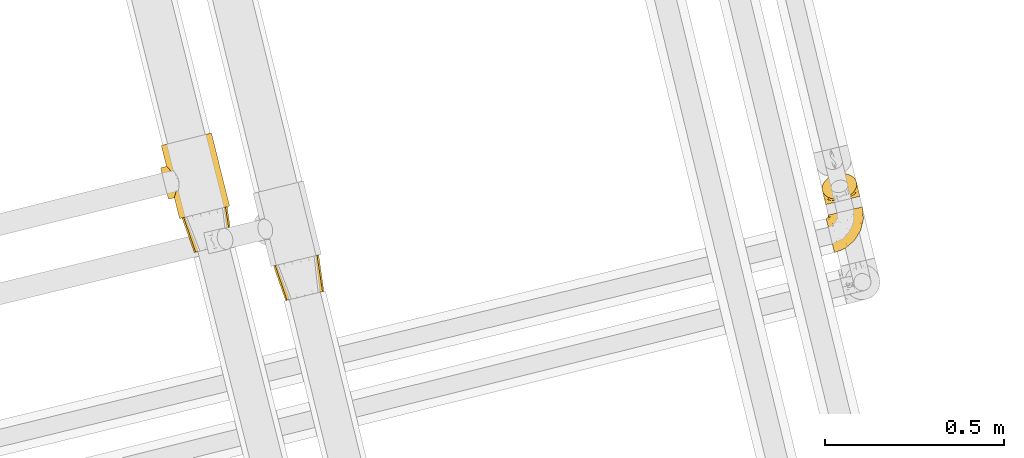
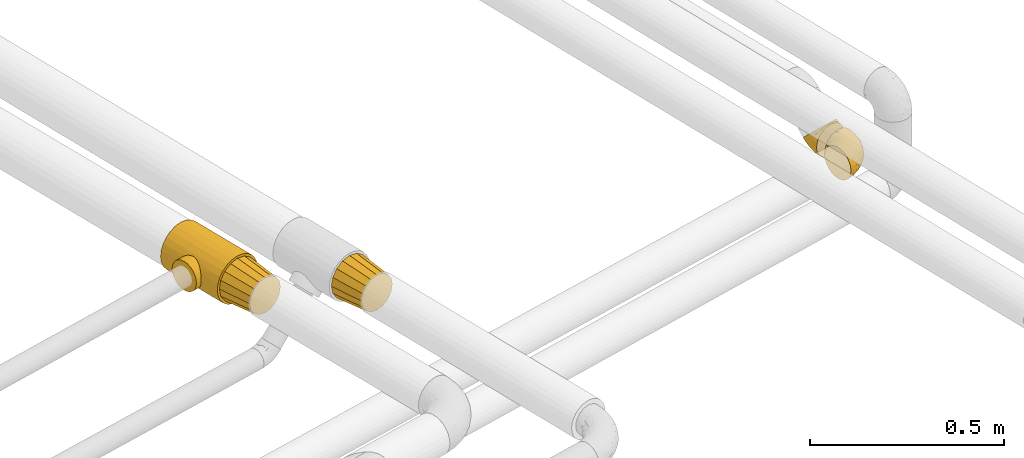
# One storey, part 7 of 93: 5 coverings.
"""IFC2X3 building model written with IfcOpenShell, lengths in millimetres."""

from ifc_helpers import new_model, entity, si_unit, converted_unit, derived_unit, direction, frame, origin, place, context, subcontext, project, spatial, faceted_brep, element, save


model = new_model("IFC2X3")

# Units and contexts
model_context = context("Model", 3, precision=0.01, world=origin(), true_north=direction((6.12303176911189e-17, 1.0)))
body_context = subcontext(model_context, "Body", "Model", "MODEL_VIEW")
ifc_project = project(units=[si_unit("LENGTHUNIT", "METRE", prefix="MILLI"), si_unit("AREAUNIT", "SQUARE_METRE"), si_unit("VOLUMEUNIT", "CUBIC_METRE"), converted_unit("PLANEANGLEUNIT", "DEGREE", entity("IfcRatioMeasure", 0.0174532925199433), si_unit("PLANEANGLEUNIT", "RADIAN"), dimensions=[0, 0, 0, 0, 0, 0, 0]), si_unit("MASSUNIT", "GRAM", prefix="KILO"), derived_unit("MASSDENSITYUNIT", [(si_unit("MASSUNIT", "GRAM", prefix="KILO"), 1), (si_unit("LENGTHUNIT", "METRE"), -3)]), derived_unit("MOMENTOFINERTIAUNIT", [(si_unit("LENGTHUNIT", "METRE"), 4)]), si_unit("TIMEUNIT", "SECOND"), si_unit("FREQUENCYUNIT", "HERTZ"), si_unit("THERMODYNAMICTEMPERATUREUNIT", "DEGREE_CELSIUS"), derived_unit("THERMALTRANSMITTANCEUNIT", [(si_unit("MASSUNIT", "GRAM", prefix="KILO"), 1), (si_unit("THERMODYNAMICTEMPERATUREUNIT", "KELVIN"), -1), (si_unit("TIMEUNIT", "SECOND"), -3)]), derived_unit("VOLUMETRICFLOWRATEUNIT", [(si_unit("LENGTHUNIT", "METRE"), 3), (si_unit("TIMEUNIT", "SECOND"), -1)]), derived_unit("MASSFLOWRATEUNIT", [(si_unit("MASSUNIT", "GRAM", prefix="KILO"), 1), (si_unit("TIMEUNIT", "SECOND"), -1)]), derived_unit("ROTATIONALFREQUENCYUNIT", [(si_unit("TIMEUNIT", "SECOND"), -1)]), si_unit("ELECTRICCURRENTUNIT", "AMPERE"), si_unit("ELECTRICVOLTAGEUNIT", "VOLT"), si_unit("POWERUNIT", "WATT"), si_unit("FORCEUNIT", "NEWTON", prefix="KILO"), si_unit("ILLUMINANCEUNIT", "LUX"), si_unit("LUMINOUSFLUXUNIT", "LUMEN"), si_unit("LUMINOUSINTENSITYUNIT", "CANDELA"), derived_unit("USERDEFINED", [(si_unit("MASSUNIT", "GRAM", prefix="KILO"), -1), (si_unit("LENGTHUNIT", "METRE"), -2), (si_unit("TIMEUNIT", "SECOND"), 3), (si_unit("LUMINOUSFLUXUNIT", "LUMEN"), 1)]), derived_unit("LINEARVELOCITYUNIT", [(si_unit("LENGTHUNIT", "METRE"), 1), (si_unit("TIMEUNIT", "SECOND"), -1)]), si_unit("PRESSUREUNIT", "PASCAL"), derived_unit("USERDEFINED", [(si_unit("LENGTHUNIT", "METRE"), -2), (si_unit("MASSUNIT", "GRAM", prefix="KILO"), 1), (si_unit("TIMEUNIT", "SECOND"), -2)]), derived_unit("LINEARFORCEUNIT", [(si_unit("MASSUNIT", "GRAM", prefix="KILO"), 1), (si_unit("LENGTHUNIT", "METRE"), 1), (si_unit("TIMEUNIT", "SECOND"), -2), (si_unit("LENGTHUNIT", "METRE"), -1)]), derived_unit("PLANARFORCEUNIT", [(si_unit("MASSUNIT", "GRAM", prefix="KILO"), 1), (si_unit("LENGTHUNIT", "METRE"), 1), (si_unit("TIMEUNIT", "SECOND"), -2), (si_unit("LENGTHUNIT", "METRE"), -2)])], contexts=[model_context])

# Site, building, storey
site_placement = place(None, origin())
site = spatial("IfcSite", under=ifc_project, at=site_placement, CompositionType="ELEMENT")
building_placement = place(site_placement, origin())
building = spatial("IfcBuilding", under=site, at=building_placement, CompositionType="ELEMENT")
storey_placement = place(building_placement, frame((0.0, 0.0, -4200.0)))
storey = spatial("IfcBuildingStorey", under=building, at=storey_placement, CompositionType="ELEMENT", Elevation=-4200.0)

# Coverings
covering_1_placement = place(storey_placement, frame((-16206.44, 9622.71, 2434.01)))
element("IfcCovering", 1, at=covering_1_placement, inside=storey, PredefinedType="INSULATION", context=body_context, shape_type="Brep", body=[
    faceted_brep([(35.52, 1.6, 66.6), (37.56, 2.09, 56.07), (39.59, 2.59, 45.55), (45.38, 4.0, 36.63), (51.17, 5.42, 27.7), (59.84, 7.54, 21.74), (68.5, 9.65, 15.78), (78.73, 12.15, 13.69), (88.95, 14.65, 11.6), (99.17, 17.15, 13.69), (109.4, 19.65, 15.78), (118.06, 21.77, 21.74), (126.73, 23.88, 27.7), (132.52, 25.3, 36.63), (138.31, 26.71, 45.55), (140.34, 27.21, 56.07), (142.38, 27.71, 66.6), (140.34, 27.21, 77.12), (138.31, 26.71, 87.64), (132.52, 25.3, 96.56), (126.73, 23.88, 105.49), (118.06, 21.77, 111.45), (109.4, 19.65, 117.41), (99.17, 17.15, 119.5), (88.95, 14.65, 121.6), (78.73, 12.15, 119.5), (68.5, 9.65, 117.41), (59.84, 7.54, 111.45), (51.17, 5.42, 105.49), (45.38, 4.0, 96.56), (39.59, 2.59, 87.64), (37.56, 2.09, 77.12), (123.07, 127.99, 91.47), (125.06, 128.48, 81.18), (127.88, 129.17, 66.6), (125.06, 128.48, 52.01), (123.07, 127.99, 41.72), (116.23, 126.32, 31.18), (109.39, 124.65, 20.63), (99.14, 122.14, 13.59), (88.9, 119.64, 6.54), (78.91, 117.2, 4.5), (64.74, 113.74, 1.6), (50.57, 110.27, 4.5), (40.57, 107.83, 6.54), (30.33, 105.33, 13.59), (20.09, 102.83, 20.63), (13.25, 101.15, 31.18), (6.4, 99.48, 41.72), (4.41, 98.99, 52.01), (1.6, 98.31, 66.6), (4.41, 98.99, 81.18), (6.4, 99.48, 91.47), (13.25, 101.15, 102.01), (20.09, 102.83, 112.56), (30.33, 105.33, 119.6), (40.57, 107.83, 126.65), (50.57, 110.27, 128.69), (64.74, 113.74, 131.6), (78.91, 117.2, 128.69), (88.9, 119.64, 126.65), (99.14, 122.14, 119.6), (109.39, 124.65, 112.56), (116.23, 126.32, 102.01)], [[[0, 1, 2, 3, 4, 5, 6, 7, 8, 9, 10, 11, 12, 13, 14, 15, 16, 17, 18, 19, 20, 21, 22, 23, 24, 25, 26, 27, 28, 29, 30, 31]], [[32, 33, 34, 35, 36, 37, 38, 39, 40, 41, 42, 43, 44, 45, 46, 47, 48, 49, 50, 51, 52, 53, 54, 55, 56, 57, 58, 59, 60, 61, 62, 63]], [[6, 44, 43, 42, 8, 7]], [[45, 44, 6, 5, 4, 46]], [[1, 0, 50, 49, 48, 2]], [[47, 46, 4, 3, 2, 48]], [[14, 36, 35, 34, 16, 15]], [[37, 36, 14, 13, 12, 38]], [[9, 8, 42, 41, 40, 10]], [[39, 38, 12, 11, 10, 40]], [[22, 60, 59, 58, 24, 23]], [[61, 60, 22, 21, 20, 62]], [[17, 16, 34, 33, 32, 18]], [[63, 62, 20, 19, 18, 32]], [[30, 52, 51, 50, 0, 31]], [[53, 52, 30, 29, 28, 54]], [[25, 24, 58, 57, 56, 26]], [[55, 54, 28, 27, 26, 56]]]),
])
covering_2_placement = place(storey_placement, frame((-16521.24, 9851.44, 2426.25)))
element("IfcCovering", 2, at=covering_2_placement, inside=storey, PredefinedType="INSULATION", context=body_context, shape_type="Brep", body=[
    faceted_brep([(91.57, 227.34, 143.44), (108.46, 231.55, 136.23), (122.95, 235.17, 124.76), (134.08, 237.95, 109.82), (141.07, 239.69, 92.42), (143.46, 240.29, 73.75), (141.07, 239.69, 55.07), (134.08, 237.95, 37.67), (122.95, 235.17, 22.73), (108.46, 231.55, 11.26), (91.57, 227.34, 4.05), (73.46, 222.82, 1.6), (55.34, 218.29, 4.05), (38.45, 214.08, 11.26), (23.96, 210.46, 22.73), (12.83, 207.69, 37.67), (9.33, 206.81, 46.37), (5.84, 205.94, 55.07), (4.64, 205.64, 64.41), (3.45, 205.35, 73.75), (4.64, 205.64, 83.08), (5.84, 205.94, 92.42), (9.33, 206.81, 101.12), (12.83, 207.69, 109.82), (23.96, 210.46, 124.76), (38.45, 214.08, 136.23), (55.34, 218.29, 143.44), (73.46, 222.82, 145.9), (124.3, 19.07, 1.6), (142.42, 23.59, 4.05), (159.31, 27.8, 11.26), (173.8, 31.42, 22.73), (184.93, 34.19, 37.67), (191.92, 35.94, 55.07), (194.31, 36.54, 73.75), (191.92, 35.94, 92.42), (184.93, 34.19, 109.82), (173.8, 31.42, 124.76), (159.31, 27.8, 136.23), (142.42, 23.59, 143.44), (124.3, 19.07, 145.9), (106.19, 14.54, 143.44), (89.3, 10.33, 136.23), (74.8, 6.71, 124.76), (63.68, 3.94, 109.82), (60.18, 3.06, 101.12), (56.69, 2.19, 92.42), (55.49, 1.89, 83.08), (54.3, 1.6, 73.75), (55.49, 1.89, 64.41), (56.69, 2.19, 55.07), (60.18, 3.06, 46.37), (63.68, 3.94, 37.67), (74.8, 6.71, 22.73), (89.3, 10.33, 11.26), (106.19, 14.54, 4.05), (45.79, 87.26, 33.18), (21.79, 143.46, 53.82), (25.99, 138.98, 45.41), (45.86, 97.11, 29.78), (40.24, 61.0, 63.43), (44.28, 107.31, 28.6), (40.88, 117.07, 29.78), (17.94, 147.28, 73.75), (18.95, 146.3, 63.43), (36.19, 125.72, 33.18), (43.01, 70.77, 45.41), (44.64, 78.37, 38.46), (41.41, 64.84, 53.82), (39.81, 59.66, 73.75), (30.99, 133.04, 38.46), (40.24, 61.0, 84.06), (41.41, 64.84, 93.68), (44.64, 78.37, 109.03), (43.01, 70.77, 102.09), (18.95, 146.3, 84.06), (21.79, 143.46, 93.68), (25.99, 138.98, 102.09), (30.99, 133.04, 109.03), (45.79, 87.26, 114.31), (45.86, 97.11, 117.71), (44.28, 107.31, 118.9), (36.19, 125.72, 114.31), (40.88, 117.07, 117.71), (20.26, 68.41, 41.82), (22.0, 61.45, 51.17), (23.09, 57.08, 62.06), (23.46, 55.58, 73.75), (23.09, 57.08, 85.43), (22.0, 61.45, 96.32), (20.26, 68.41, 105.67), (17.99, 77.49, 112.85), (15.36, 88.05, 117.36), (12.53, 99.39, 118.9), (9.7, 110.73, 117.36), (7.06, 121.29, 112.85), (4.8, 130.37, 105.67), (3.06, 137.33, 96.32), (1.97, 141.7, 85.43), (1.6, 143.2, 73.75), (1.97, 141.7, 62.06), (3.06, 137.33, 51.17), (4.8, 130.37, 41.82), (7.06, 121.29, 34.64), (9.7, 110.73, 30.13), (12.53, 99.39, 28.6), (15.36, 88.05, 30.13), (17.99, 77.49, 34.64)], [[[0, 1, 2, 3, 4, 5, 6, 7, 8, 9, 10, 11, 12, 13, 14, 15, 16, 17, 18, 19, 20, 21, 22, 23, 24, 25, 26, 27]], [[28, 29, 30, 31, 32, 33, 34, 35, 36, 37, 38, 39, 40, 41, 42, 43, 44, 45, 46, 47, 48, 49, 50, 51, 52, 53, 54, 55]], [[32, 31, 8, 7]], [[5, 34, 33, 6]], [[6, 33, 32, 7]], [[9, 30, 29, 10]], [[10, 29, 28, 11]], [[8, 31, 30, 9]], [[55, 12, 11, 28]], [[54, 13, 12, 55]], [[53, 52, 56]], [[57, 16, 58]], [[56, 59, 53]], [[60, 50, 49]], [[54, 53, 14, 13]], [[53, 59, 61]], [[61, 62, 14]], [[63, 18, 64]], [[14, 65, 15]], [[65, 14, 62]], [[66, 52, 51]], [[14, 53, 61]], [[56, 52, 67]], [[67, 52, 66]], [[66, 51, 68]], [[48, 69, 49]], [[63, 19, 18]], [[60, 49, 69]], [[50, 60, 68]], [[50, 68, 51]], [[70, 58, 15]], [[16, 57, 17]], [[58, 16, 15]], [[15, 65, 70]], [[18, 17, 64]], [[64, 17, 57]], [[48, 47, 69]], [[63, 20, 19]], [[71, 47, 46]], [[46, 72, 71]], [[46, 45, 72]], [[44, 73, 74]], [[74, 45, 44]], [[75, 20, 63]], [[76, 22, 21]], [[76, 77, 22]], [[76, 21, 75]], [[77, 78, 23]], [[79, 43, 80]], [[43, 79, 44]], [[69, 47, 71]], [[72, 45, 74]], [[42, 41, 26, 25]], [[24, 43, 42, 25]], [[80, 43, 81]], [[26, 41, 40, 27]], [[24, 82, 83]], [[75, 21, 20]], [[24, 23, 82]], [[23, 78, 82]], [[83, 81, 24]], [[77, 23, 22]], [[81, 43, 24]], [[79, 73, 44]], [[0, 39, 38, 1]], [[1, 38, 37, 2]], [[40, 39, 0, 27]], [[3, 36, 35, 4]], [[4, 35, 34, 5]], [[2, 37, 36, 3]], [[84, 85, 86, 87, 88, 89, 90, 91, 92, 93, 94, 95, 96, 97, 98, 99, 100, 101, 102, 103, 104, 105, 106, 107]], [[60, 87, 86]], [[68, 86, 85]], [[60, 69, 87]], [[66, 68, 85]], [[60, 86, 68]], [[85, 84, 66]], [[84, 107, 67]], [[107, 106, 56]], [[59, 106, 105]], [[67, 107, 56]], [[59, 56, 106]], [[61, 59, 105]], [[84, 67, 66]], [[62, 105, 104]], [[65, 104, 103]], [[61, 105, 62]], [[62, 104, 65]], [[103, 70, 65]], [[103, 102, 70]], [[58, 102, 101]], [[100, 99, 64]], [[57, 101, 100]], [[57, 58, 101]], [[63, 64, 99]], [[57, 100, 64]], [[102, 58, 70]], [[75, 99, 98]], [[76, 98, 97]], [[75, 63, 99]], [[77, 76, 97]], [[75, 98, 76]], [[97, 96, 77]], [[78, 96, 95]], [[95, 94, 82]], [[93, 83, 94]], [[78, 95, 82]], [[83, 82, 94]], [[81, 83, 93]], [[96, 78, 77]], [[80, 93, 92]], [[79, 92, 91]], [[81, 93, 80]], [[80, 92, 79]], [[91, 73, 79]], [[91, 90, 73]], [[74, 90, 89]], [[89, 88, 72]], [[87, 71, 88]], [[72, 74, 89]], [[69, 71, 87]], [[72, 88, 71]], [[90, 74, 73]]]),
])
covering_3_placement = place(storey_placement, frame((-16461.59, 9756.63, 2433.4)))
element("IfcCovering", 3, at=covering_3_placement, inside=storey, PredefinedType="INSULATION", context=body_context, shape_type="Brep", body=[
    faceted_brep([(36.0, 1.6, 66.6), (38.03, 2.1, 56.07), (40.06, 2.61, 45.55), (45.84, 4.05, 36.63), (51.63, 5.5, 27.7), (60.28, 7.66, 21.74), (68.94, 9.82, 15.78), (79.15, 12.36, 13.69), (89.36, 14.91, 11.6), (99.57, 17.46, 13.69), (109.78, 20.01, 15.78), (118.44, 22.17, 21.74), (127.09, 24.33, 27.7), (132.88, 25.77, 36.63), (138.66, 27.22, 45.55), (140.69, 27.72, 56.07), (142.72, 28.23, 66.6), (140.69, 27.72, 77.12), (138.66, 27.22, 87.64), (132.88, 25.77, 96.56), (127.09, 24.33, 105.49), (118.44, 22.17, 111.45), (109.78, 20.01, 117.41), (99.57, 17.46, 119.5), (89.36, 14.91, 121.6), (79.15, 12.36, 119.5), (68.94, 9.82, 117.41), (60.28, 7.66, 111.45), (51.63, 5.5, 105.49), (45.84, 4.05, 96.56), (40.06, 2.61, 87.64), (38.03, 2.1, 77.12), (122.93, 128.42, 91.47), (124.91, 128.91, 81.18), (127.73, 129.62, 66.6), (124.91, 128.91, 52.01), (122.93, 128.42, 41.72), (116.09, 126.71, 31.18), (109.26, 125.01, 20.63), (99.03, 122.45, 13.59), (88.8, 119.9, 6.54), (78.81, 117.41, 4.5), (64.66, 113.88, 1.6), (50.51, 110.35, 4.5), (40.53, 107.85, 6.54), (30.3, 105.3, 13.59), (20.07, 102.75, 20.63), (13.23, 101.04, 31.18), (6.4, 99.34, 41.72), (4.41, 98.84, 52.01), (1.6, 98.14, 66.6), (4.41, 98.84, 81.18), (6.4, 99.34, 91.47), (13.23, 101.04, 102.01), (20.07, 102.75, 112.56), (30.3, 105.3, 119.6), (40.53, 107.85, 126.65), (50.51, 110.35, 128.69), (64.66, 113.88, 131.6), (78.81, 117.41, 128.69), (88.8, 119.9, 126.65), (99.03, 122.45, 119.6), (109.26, 125.01, 112.56), (116.09, 126.71, 102.01)], [[[0, 1, 2, 3, 4, 5, 6, 7, 8, 9, 10, 11, 12, 13, 14, 15, 16, 17, 18, 19, 20, 21, 22, 23, 24, 25, 26, 27, 28, 29, 30, 31]], [[32, 33, 34, 35, 36, 37, 38, 39, 40, 41, 42, 43, 44, 45, 46, 47, 48, 49, 50, 51, 52, 53, 54, 55, 56, 57, 58, 59, 60, 61, 62, 63]], [[6, 44, 43, 42, 8, 7]], [[45, 44, 6, 5, 4, 46]], [[1, 0, 50, 49, 48, 2]], [[47, 46, 4, 3, 2, 48]], [[14, 36, 35, 34, 16, 15]], [[37, 36, 14, 13, 12, 38]], [[9, 8, 42, 41, 40, 10]], [[39, 38, 12, 11, 10, 40]], [[22, 60, 59, 58, 24, 23]], [[61, 60, 22, 21, 20, 62]], [[17, 16, 34, 33, 32, 18]], [[63, 62, 20, 19, 18, 32]], [[30, 52, 51, 50, 0, 31]], [[53, 52, 30, 29, 28, 54]], [[25, 24, 58, 57, 56, 26]], [[55, 54, 28, 27, 26, 56]]]),
])
covering_4_placement = place(storey_placement, frame((-14665.38, 9756.17, 2242.1)))
element("IfcCovering", 4, at=covering_4_placement, inside=storey, PredefinedType="INSULATION", context=body_context, shape_type="Brep", body=[
    faceted_brep([(8.57, 106.85, 61.69), (12.1, 107.7, 72.08), (17.8, 109.07, 81.4), (25.37, 110.89, 89.18), (34.43, 113.07, 95.03), (39.48, 114.29, 96.85), (44.53, 115.5, 98.66), (49.6, 116.72, 99.25), (52.38, 117.39, 99.57), (55.16, 118.06, 99.9), (65.79, 120.62, 98.66), (75.9, 123.05, 95.02), (84.96, 125.22, 89.17), (92.52, 127.04, 81.38), (98.21, 128.41, 72.06), (101.75, 129.26, 61.68), (102.94, 129.55, 50.75), (101.74, 129.26, 39.8), (98.21, 128.41, 29.41), (92.51, 127.04, 20.09), (84.94, 125.22, 12.31), (75.88, 123.04, 6.46), (65.78, 120.61, 2.83), (55.16, 118.06, 1.6), (49.6, 116.72, 2.24), (44.52, 115.5, 2.83), (39.47, 114.28, 4.65), (34.41, 113.07, 6.47), (25.35, 110.89, 12.32), (17.79, 109.07, 20.11), (12.1, 107.7, 29.43), (8.57, 106.85, 39.81), (7.37, 106.56, 50.75), (1.99, 95.47, 38.02), (3.15, 90.7, 26.17), (5.0, 83.11, 15.99), (6.21, 78.17, 12.09), (7.42, 73.22, 8.18), (8.82, 67.46, 5.73), (10.22, 61.71, 3.27), (11.87, 54.93, 2.35), (12.55, 52.14, 1.97), (13.23, 49.35, 1.6), (16.25, 36.99, 3.27), (19.05, 25.47, 8.18), (21.47, 15.58, 15.99), (23.32, 7.99, 26.17), (24.48, 3.22, 38.02), (24.87, 1.6, 50.75), (24.48, 3.22, 63.47), (23.32, 7.99, 75.32), (21.47, 15.58, 85.5), (19.05, 25.47, 93.31), (16.25, 36.99, 98.22), (13.23, 49.35, 99.9), (11.87, 54.93, 99.14), (10.22, 61.71, 98.22), (8.82, 67.46, 95.77), (7.42, 73.22, 93.31), (6.21, 78.17, 89.4), (5.0, 83.11, 85.5), (3.15, 90.7, 75.32), (1.99, 95.47, 63.47), (1.6, 97.1, 50.75), (85.07, 42.86, 59.29), (75.55, 38.34, 73.11), (70.31, 27.79, 63.74), (55.46, 14.38, 50.75), (45.32, 9.57, 58.65), (36.17, 6.31, 50.75), (59.86, 26.44, 76.75), (47.39, 13.26, 67.69), (40.37, 16.35, 78.93), (77.12, 85.51, 94.32), (67.08, 99.78, 98.75), (63.62, 78.57, 98.4), (39.29, 36.05, 94.57), (60.86, 43.25, 89.92), (57.67, 56.53, 96.34), (33.98, 46.7, 98.79), (33.36, 58.7, 99.9), (28.31, 56.35, 99.9), (23.26, 54.01, 99.9), (20.75, 52.84, 99.9), (18.25, 51.68, 99.9), (44.59, 26.89, 87.32), (76.82, 104.98, 95.6), (102.15, 80.75, 60.46), (103.7, 104.3, 65.24), (98.54, 84.36, 72.88), (56.05, 95.88, 99.9), (54.13, 90.67, 99.9), (52.22, 85.46, 99.9), (50.31, 80.25, 99.9), (48.39, 75.04, 99.9), (85.43, 105.8, 90.65), (96.24, 64.44, 63.07), (70.33, 59.5, 91.92), (99.21, 109.79, 75.25), (103.91, 117.35, 50.75), (68.93, 39.98, 82.2), (78.56, 57.02, 85.12), (84.2, 53.86, 76.93), (97.87, 64.27, 50.75), (89.24, 50.12, 50.75), (93.75, 101.47, 83.02), (55.27, 115.3, 99.9), (55.38, 112.53, 99.9), (55.6, 107.01, 99.9), (55.82, 101.44, 99.9), (87.03, 82.69, 87.14), (89.33, 70.42, 80.75), (49.08, 61.78, 99.17), (105.57, 96.51, 50.75), (44.64, 70.95, 99.9), (40.88, 66.87, 99.9), (37.12, 62.79, 99.9), (80.61, 35.97, 50.75), (87.82, 50.99, 67.57), (93.44, 66.4, 72.15), (101.72, 80.39, 50.75), (68.03, 25.17, 50.75), (45.87, 106.91, 98.69), (17.88, 60.57, 99.01), (26.18, 66.37, 98.78), (19.79, 64.96, 98.29), (20.32, 101.11, 84.1), (11.91, 103.41, 71.06), (44.2, 94.88, 98.54), (48.56, 97.63, 99.29), (13.26, 81.62, 89.5), (10.44, 87.32, 83.58), (9.04, 93.38, 75.73), (15.35, 89.89, 84.78), (13.04, 98.33, 75.87), (7.24, 98.27, 64.77), (25.29, 91.99, 90.82), (32.38, 92.49, 94.63), (26.92, 98.35, 90.37), (11.51, 78.16, 91.18), (25.42, 104.19, 88.63), (23.51, 86.94, 91.61), (18.82, 96.65, 83.9), (39.71, 103.8, 96.86), (6.44, 100.64, 50.75), (8.81, 102.34, 62.92), (41.78, 89.08, 98.37), (42.42, 83.52, 99.0), (35.41, 83.67, 97.36), (18.85, 73.31, 95.54), (30.23, 69.65, 98.76), (22.91, 76.97, 95.26), (33.3, 76.9, 98.03), (18.78, 83.86, 90.61), (32.44, 103.91, 93.48), (33.04, 98.11, 94.16), (34.82, 71.69, 99.1), (9.04, 93.38, 25.76), (18.76, 83.86, 10.89), (10.43, 87.32, 17.9), (15.33, 89.88, 16.72), (11.9, 103.41, 30.45), (13.26, 81.61, 11.98), (39.69, 103.8, 4.64), (20.31, 101.11, 17.4), (15.74, 50.51, 1.6), (23.26, 54.01, 1.6), (18.25, 51.68, 1.6), (25.4, 104.18, 12.88), (26.91, 98.34, 11.13), (19.79, 64.96, 3.2), (18.85, 73.31, 5.95), (11.51, 78.16, 10.31), (32.4, 103.92, 8.04), (43.88, 95.04, 3.03), (33.02, 98.11, 7.34), (17.88, 60.57, 2.48), (30.23, 69.65, 2.73), (26.51, 66.16, 2.63), (55.6, 107.01, 1.6), (45.87, 106.9, 2.8), (7.23, 98.26, 36.71), (28.31, 56.35, 1.6), (33.36, 58.7, 1.6), (8.8, 102.34, 38.59), (55.38, 112.53, 1.6), (55.49, 109.77, 1.6), (41.78, 89.08, 3.12), (18.81, 96.65, 17.6), (50.31, 80.25, 1.6), (42.39, 83.51, 2.5), (32.38, 92.47, 6.86), (33.3, 76.9, 3.46), (23.48, 86.94, 9.9), (35.34, 83.69, 4.15), (55.82, 101.44, 1.6), (56.05, 95.88, 1.6), (13.03, 98.33, 25.63), (25.27, 91.98, 10.68), (34.82, 71.7, 2.39), (40.88, 66.87, 1.6), (22.91, 76.97, 6.23), (37.12, 62.79, 1.6), (48.56, 97.63, 2.2), (44.64, 70.95, 1.6), (48.39, 75.04, 1.6), (52.22, 85.46, 1.6), (54.13, 90.67, 1.6), (49.44, 61.56, 2.4), (45.32, 9.57, 42.84), (44.6, 26.89, 14.17), (60.63, 43.07, 11.55), (68.89, 39.97, 19.26), (59.86, 26.45, 24.74), (75.56, 38.39, 28.35), (76.96, 105.26, 5.95), (67.35, 99.64, 2.8), (33.98, 46.7, 2.7), (70.31, 27.79, 37.75), (47.4, 13.26, 33.8), (40.38, 16.36, 22.56), (39.29, 36.05, 6.92), (98.54, 84.36, 28.6), (103.69, 104.3, 36.23), (102.14, 80.74, 41.02), (84.24, 53.94, 24.55), (87.82, 50.99, 33.92), (77.15, 86.19, 7.1), (96.24, 64.4, 38.45), (85.07, 42.86, 42.2), (93.73, 101.47, 18.45), (85.41, 105.79, 10.83), (89.39, 70.5, 20.79), (93.46, 66.41, 29.36), (63.65, 78.56, 3.1), (73.1, 65.46, 9.17), (99.2, 109.78, 26.22), (86.97, 82.5, 14.34), (58.29, 56.15, 5.45), (78.55, 57.03, 16.36)], [[[0, 1, 2, 3, 4, 5, 6, 7, 8, 9, 10, 11, 12, 13, 14, 15, 16, 17, 18, 19, 20, 21, 22, 23, 24, 25, 26, 27, 28, 29, 30, 31, 32]], [[33, 34, 35, 36, 37, 38, 39, 40, 41, 42, 43, 44, 45, 46, 47, 48, 49, 50, 51, 52, 53, 54, 55, 56, 57, 58, 59, 60, 61, 62, 63]], [[64, 65, 66]], [[67, 68, 69]], [[66, 70, 71]], [[71, 70, 72]], [[73, 74, 75]], [[76, 77, 78]], [[50, 49, 71]], [[79, 80, 81, 82, 83, 84, 54]], [[51, 85, 52]], [[72, 51, 50]], [[11, 10, 86]], [[87, 88, 89]], [[75, 90, 91, 92, 93, 94]], [[54, 53, 79]], [[76, 52, 85]], [[14, 88, 15]], [[86, 74, 73]], [[95, 12, 11]], [[87, 89, 96]], [[97, 78, 77]], [[88, 14, 98]], [[72, 85, 51]], [[98, 14, 13]], [[88, 99, 15]], [[77, 100, 101]], [[100, 65, 102]], [[103, 96, 104]], [[105, 13, 12]], [[74, 9, 106, 107, 108, 109, 90]], [[105, 110, 111]], [[112, 75, 94]], [[87, 113, 88]], [[112, 94, 114, 115, 116, 80]], [[73, 95, 86]], [[117, 64, 66]], [[49, 69, 68]], [[98, 89, 88]], [[97, 75, 78]], [[100, 102, 101]], [[95, 105, 12]], [[78, 79, 76]], [[105, 95, 110]], [[66, 71, 68]], [[64, 96, 118]], [[76, 79, 53]], [[112, 79, 78]], [[52, 76, 53]], [[76, 85, 77]], [[100, 85, 70]], [[77, 101, 97]], [[13, 105, 98]], [[89, 98, 105]], [[86, 95, 11]], [[110, 95, 73]], [[97, 110, 73]], [[101, 102, 111]], [[89, 119, 96]], [[87, 103, 120, 113]], [[99, 88, 113]], [[99, 16, 15]], [[86, 10, 74]], [[9, 74, 10]], [[90, 75, 74]], [[71, 72, 50]], [[85, 72, 70]], [[79, 112, 80]], [[75, 112, 78]], [[85, 100, 77]], [[65, 100, 70]], [[66, 65, 70]], [[65, 118, 102]], [[118, 119, 102]], [[102, 119, 111]], [[119, 118, 96]], [[89, 105, 111]], [[89, 111, 119]], [[101, 111, 110]], [[104, 96, 64]], [[103, 87, 96]], [[104, 64, 117]], [[65, 64, 118]], [[66, 67, 121, 117]], [[49, 48, 69]], [[49, 68, 71]], [[110, 97, 101]], [[75, 97, 73]], [[67, 66, 68]], [[5, 122, 108]], [[82, 81, 123]], [[124, 80, 116]], [[58, 57, 125]], [[126, 1, 127]], [[128, 91, 129]], [[60, 130, 131]], [[132, 133, 134]], [[135, 63, 62]], [[62, 132, 135]], [[136, 137, 138]], [[109, 108, 122, 90]], [[132, 134, 135]], [[132, 62, 61]], [[130, 60, 139]], [[123, 57, 56]], [[140, 126, 138]], [[140, 2, 126]], [[125, 81, 80]], [[4, 122, 5]], [[106, 9, 8, 7, 6, 108, 107]], [[6, 5, 108]], [[141, 136, 142]], [[4, 143, 122]], [[56, 55, 54, 84, 83, 82]], [[144, 145, 32]], [[145, 135, 134]], [[1, 126, 2]], [[93, 92, 146]], [[1, 0, 127]], [[142, 136, 126]], [[122, 143, 129]], [[125, 57, 123]], [[147, 137, 148]], [[125, 124, 149]], [[149, 58, 125]], [[150, 149, 124]], [[151, 152, 153]], [[151, 130, 139]], [[143, 4, 3]], [[140, 154, 3]], [[155, 146, 128]], [[131, 61, 60]], [[132, 131, 133]], [[134, 127, 145]], [[63, 135, 144]], [[156, 150, 115]], [[150, 116, 115]], [[151, 149, 150]], [[156, 114, 152]], [[141, 148, 136]], [[151, 150, 156]], [[130, 151, 153]], [[130, 153, 131]], [[139, 60, 59]], [[133, 131, 153]], [[132, 61, 131]], [[141, 133, 153]], [[141, 142, 133]], [[153, 152, 141]], [[148, 141, 152]], [[152, 94, 148]], [[146, 92, 128]], [[80, 124, 125]], [[116, 150, 124]], [[94, 93, 147]], [[137, 146, 155]], [[147, 93, 146]], [[91, 90, 129]], [[128, 143, 154]], [[128, 92, 91]], [[127, 0, 145]], [[127, 134, 142]], [[32, 145, 0]], [[144, 135, 145]], [[82, 123, 56]], [[125, 123, 81]], [[138, 137, 155]], [[148, 137, 136]], [[138, 155, 140]], [[136, 138, 126]], [[154, 140, 155]], [[3, 2, 140]], [[128, 154, 155]], [[143, 3, 154]], [[122, 129, 90]], [[128, 129, 143]], [[127, 142, 126]], [[133, 142, 134]], [[59, 149, 139]], [[58, 149, 59]], [[139, 149, 151]], [[114, 94, 152]], [[151, 156, 152]], [[156, 115, 114]], [[137, 147, 146]], [[94, 147, 148]], [[34, 33, 157]], [[158, 159, 160]], [[31, 30, 161]], [[35, 159, 162]], [[28, 27, 163]], [[164, 30, 29]], [[165, 42, 41, 40, 39, 166, 167]], [[168, 169, 164]], [[170, 37, 171]], [[36, 35, 172]], [[173, 174, 175]], [[39, 176, 166]], [[177, 178, 171]], [[26, 179, 180]], [[63, 144, 181]], [[182, 170, 183]], [[32, 31, 184]], [[170, 38, 37]], [[24, 23, 185, 186, 179, 25]], [[176, 39, 38]], [[187, 175, 174]], [[188, 161, 164]], [[33, 181, 157]], [[175, 169, 168]], [[189, 190, 187]], [[27, 180, 163]], [[169, 175, 191]], [[192, 193, 194]], [[195, 196, 180, 179]], [[179, 26, 25]], [[27, 26, 180]], [[197, 157, 181]], [[188, 164, 198]], [[184, 161, 197]], [[199, 200, 177]], [[182, 176, 170]], [[158, 201, 162]], [[202, 178, 177]], [[202, 177, 200]], [[196, 203, 180]], [[203, 174, 163]], [[168, 173, 175]], [[197, 188, 160]], [[162, 159, 158]], [[63, 181, 33]], [[161, 184, 31]], [[171, 201, 177]], [[170, 178, 183]], [[201, 192, 199]], [[193, 158, 160]], [[192, 204, 199]], [[36, 172, 171]], [[192, 201, 158]], [[172, 201, 171]], [[159, 35, 34]], [[34, 157, 159]], [[160, 159, 157]], [[197, 160, 157]], [[160, 188, 193]], [[194, 193, 198]], [[192, 158, 193]], [[187, 191, 175]], [[205, 192, 194]], [[183, 178, 202]], [[171, 178, 170]], [[187, 206, 189]], [[205, 194, 190]], [[191, 194, 198]], [[164, 161, 30]], [[206, 187, 174]], [[207, 203, 196]], [[207, 206, 174]], [[184, 197, 181]], [[181, 144, 184]], [[32, 184, 144]], [[170, 176, 38]], [[166, 176, 182]], [[191, 187, 190]], [[169, 198, 164]], [[198, 169, 191]], [[168, 164, 29]], [[29, 28, 168]], [[173, 168, 28]], [[28, 163, 173]], [[174, 173, 163]], [[174, 203, 207]], [[180, 203, 163]], [[188, 198, 193]], [[161, 188, 197]], [[171, 37, 36]], [[35, 162, 172]], [[201, 172, 162]], [[201, 199, 177]], [[205, 190, 189]], [[204, 192, 205]], [[204, 200, 199]], [[191, 190, 194]], [[208, 183, 202, 200, 204, 205]], [[47, 209, 69]], [[210, 211, 212]], [[213, 212, 214]], [[215, 216, 22]], [[217, 42, 165, 167, 166, 182, 183]], [[218, 219, 213]], [[46, 45, 220]], [[209, 47, 219]], [[210, 221, 211]], [[221, 44, 43]], [[220, 219, 46]], [[46, 219, 47]], [[220, 210, 213]], [[222, 223, 224]], [[210, 45, 44]], [[225, 226, 214]], [[42, 217, 43]], [[216, 215, 227]], [[226, 228, 229]], [[23, 22, 216]], [[223, 18, 17]], [[19, 230, 20]], [[20, 231, 21]], [[232, 222, 233]], [[234, 205, 189, 206, 207, 196]], [[235, 234, 227]], [[221, 43, 217]], [[104, 229, 228]], [[223, 236, 18]], [[231, 237, 227]], [[18, 236, 19]], [[113, 223, 99]], [[238, 234, 235]], [[231, 20, 230]], [[222, 230, 236]], [[223, 17, 99]], [[222, 228, 233]], [[224, 113, 120, 103]], [[215, 21, 231]], [[208, 234, 238]], [[209, 218, 67]], [[218, 213, 214]], [[229, 117, 218]], [[208, 217, 183]], [[238, 211, 221]], [[238, 221, 217]], [[44, 221, 210]], [[235, 211, 238]], [[212, 211, 239]], [[222, 236, 223]], [[230, 19, 236]], [[237, 231, 230]], [[215, 231, 227]], [[232, 230, 222]], [[235, 237, 239]], [[113, 224, 223]], [[233, 228, 226]], [[17, 16, 99]], [[234, 208, 205]], [[217, 208, 238]], [[216, 227, 234]], [[22, 21, 215]], [[234, 196, 216]], [[216, 196, 195, 179, 186, 185, 23]], [[210, 220, 45]], [[219, 220, 213]], [[69, 209, 67]], [[69, 48, 47]], [[218, 209, 219]], [[225, 214, 212]], [[210, 212, 213]], [[225, 212, 239]], [[214, 226, 229]], [[232, 239, 237]], [[233, 226, 225]], [[232, 233, 225]], [[228, 222, 224]], [[239, 232, 225]], [[232, 237, 230]], [[224, 103, 228]], [[228, 103, 104]], [[104, 117, 229]], [[121, 67, 218, 117]], [[214, 229, 218]], [[237, 235, 227]], [[211, 235, 239]]]),
])
covering_5_placement = place(storey_placement, frame((-14676.7, 9890.49, 2242.1)))
element("IfcCovering", 5, at=covering_5_placement, inside=storey, PredefinedType="INSULATION", context=body_context, shape_type="Brep", body=[
    faceted_brep([(58.12, 18.49, 102.19), (68.56, 21.89, 101.32), (78.06, 26.82, 98.75), (86.15, 33.03, 94.61), (92.43, 40.2, 89.1), (96.58, 47.98, 82.51), (98.39, 55.97, 75.17), (97.78, 63.77, 67.44), (94.77, 71.01, 59.7), (89.52, 77.3, 52.36), (82.28, 82.34, 45.77), (73.43, 85.86, 40.26), (63.4, 87.71, 36.13), (52.7, 87.78, 33.56), (41.87, 86.07, 32.69), (31.43, 82.66, 33.56), (21.93, 77.73, 36.13), (13.84, 71.52, 40.27), (7.56, 64.35, 45.78), (3.41, 56.58, 52.37), (1.6, 48.59, 59.71), (2.21, 40.78, 67.44), (5.22, 33.55, 75.18), (10.47, 27.26, 82.52), (17.71, 22.22, 89.11), (26.56, 18.69, 94.62), (36.59, 16.85, 98.76), (47.29, 16.78, 101.32), (47.05, 10.11, 98.22), (35.53, 7.34, 93.31), (25.63, 4.96, 85.5), (18.03, 3.14, 75.32), (13.26, 1.99, 63.47), (12.77, 1.87, 59.62), (11.63, 1.6, 50.75), (13.26, 1.99, 38.02), (18.03, 3.14, 26.17), (25.63, 4.96, 15.99), (35.53, 7.34, 8.18), (47.05, 10.11, 3.27), (59.42, 13.09, 1.6), (71.79, 16.06, 3.27), (83.31, 18.84, 8.18), (93.21, 21.22, 15.99), (100.8, 23.04, 26.17), (105.58, 24.19, 38.02), (107.21, 24.58, 50.75), (106.07, 24.31, 59.62), (105.58, 24.19, 63.47), (103.19, 23.62, 69.39), (100.8, 23.04, 75.32), (93.21, 21.22, 85.5), (83.31, 18.84, 93.31), (71.79, 16.06, 98.22), (59.42, 13.09, 99.9), (80.67, 68.77, 29.05), (52.99, 39.8, 5.21), (63.67, 32.15, 3.82), (83.24, 38.1, 12.9), (72.08, 37.49, 7.13), (74.06, 56.4, 15.87), (91.01, 39.39, 20.1), (59.87, 52.99, 9.95), (90.53, 54.91, 29.0), (83.18, 53.18, 20.01), (95.24, 59.28, 41.95), (98.61, 41.06, 32.31), (101.26, 44.36, 43.35), (98.68, 57.64, 53.13), (102.1, 45.79, 55.08), (70.71, 73.77, 26.09), (61.47, 70.5, 20.08), (47.01, 64.69, 15.82), (87.92, 69.57, 38.7), (103.39, 40.46, 53.99), (104.67, 35.12, 52.9), (105.3, 32.49, 52.36), (105.94, 29.85, 51.82), (98.85, 59.3, 64.37), (99.93, 54.84, 61.3), (101.02, 50.32, 58.19), (76.66, 22.03, 97.11), (101.81, 38.34, 67.29), (103.62, 31.67, 64.71), (101.27, 44.82, 65.8), (99.7, 39.76, 73.34), (87.6, 27.5, 90.61), (93.5, 27.2, 84.43), (96.8, 34.29, 79.81), (104.87, 28.8, 62.16), (99.38, 53.25, 70.51), (100.31, 49.62, 67.49), (67.62, 18.29, 99.62), (99.23, 29.32, 76.08), (93.0, 35.83, 86.26), (98.8, 43.62, 75.44), (58.72, 16.01, 100.49), (22.65, 10.17, 84.44), (27.79, 13.11, 90.63), (16.58, 9.44, 76.08), (49.76, 14.0, 99.62), (40.01, 13.21, 97.12), (3.28, 36.32, 64.37), (16.5, 14.97, 79.83), (10.36, 6.86, 51.82), (11.08, 7.29, 59.87), (19.19, 18.06, 86.27), (11.6, 9.53, 64.71), (6.53, 22.8, 55.08), (10.19, 16.31, 67.31), (7.72, 22.31, 65.81), (7.81, 17.47, 53.99), (10.47, 22.36, 75.46), (4.36, 31.85, 61.3), (5.56, 30.68, 70.51), (6.39, 27.03, 67.5), (11.43, 18.52, 73.35), (5.44, 27.33, 58.19), (9.1, 12.13, 52.9), (6.51, 37.93, 41.96), (7.93, 21.92, 43.36), (15.16, 53.0, 29.06), (11.79, 20.17, 32.32), (12.69, 36.18, 29.02), (44.19, 36.52, 5.84), (37.05, 29.07, 7.14), (26.83, 24.53, 12.9), (26.67, 45.0, 15.88), (4.19, 34.91, 53.14), (19.32, 22.15, 20.1), (8.35, 50.42, 38.71), (35.6, 46.95, 11.42), (31.48, 63.28, 20.08), (21.76, 61.99, 26.09), (20.02, 37.99, 20.01)], [[[0, 1, 2, 3, 4, 5, 6, 7, 8, 9, 10, 11, 12, 13, 14, 15, 16, 17, 18, 19, 20, 21, 22, 23, 24, 25, 26, 27]], [[28, 29, 30, 31, 32, 33, 34, 35, 36, 37, 38, 39, 40, 41, 42, 43, 44, 45, 46, 47, 48, 49, 50, 51, 52, 53, 54]], [[10, 55, 11]], [[40, 56, 57]], [[42, 58, 43]], [[59, 60, 58]], [[61, 44, 43]], [[60, 59, 62]], [[63, 61, 64]], [[63, 65, 66]], [[67, 46, 45]], [[66, 67, 45]], [[42, 41, 59]], [[67, 68, 69]], [[58, 61, 43]], [[70, 60, 71]], [[71, 62, 72]], [[72, 13, 71]], [[55, 70, 11]], [[12, 70, 71]], [[59, 58, 42]], [[14, 13, 72]], [[73, 55, 10]], [[67, 69, 74, 75, 76, 77, 46]], [[41, 57, 59]], [[68, 7, 78, 79, 80, 69]], [[9, 8, 65]], [[73, 65, 63]], [[45, 44, 66]], [[67, 66, 65]], [[9, 73, 10]], [[57, 62, 59]], [[68, 65, 8]], [[12, 71, 13]], [[60, 55, 64]], [[66, 44, 61]], [[64, 61, 58]], [[61, 63, 66]], [[60, 64, 58]], [[63, 64, 55]], [[65, 73, 9]], [[55, 73, 63]], [[65, 68, 67]], [[7, 68, 8]], [[11, 70, 12]], [[55, 60, 70]], [[40, 57, 41]], [[62, 57, 56]], [[72, 62, 56]], [[62, 71, 60]], [[52, 81, 53]], [[82, 83, 74]], [[84, 85, 82]], [[86, 87, 88]], [[77, 89, 48]], [[87, 52, 51]], [[90, 5, 91]], [[92, 1, 0]], [[86, 2, 81]], [[54, 53, 92]], [[52, 86, 81]], [[93, 51, 50]], [[87, 51, 93]], [[83, 93, 50]], [[94, 95, 4]], [[5, 4, 95]], [[5, 95, 91]], [[7, 6, 78]], [[94, 88, 85]], [[86, 94, 3]], [[48, 47, 46, 77]], [[96, 92, 0]], [[80, 91, 84]], [[2, 1, 81]], [[3, 2, 86]], [[90, 78, 6]], [[1, 92, 81]], [[94, 86, 88]], [[82, 93, 83]], [[3, 94, 4]], [[80, 84, 69]], [[82, 88, 93]], [[49, 48, 89]], [[69, 82, 74]], [[83, 75, 74]], [[88, 87, 93]], [[52, 87, 86]], [[91, 80, 79]], [[91, 79, 90]], [[84, 91, 95]], [[85, 84, 95]], [[69, 84, 82]], [[78, 90, 79]], [[5, 90, 6]], [[94, 85, 95]], [[82, 85, 88]], [[54, 92, 96]], [[81, 92, 53]], [[83, 89, 75]], [[77, 76, 75, 89]], [[83, 49, 89]], [[83, 50, 49]], [[97, 29, 98]], [[30, 99, 31]], [[100, 101, 28]], [[22, 21, 102]], [[103, 99, 97]], [[101, 29, 28]], [[104, 33, 105]], [[98, 106, 103]], [[107, 31, 99]], [[97, 99, 30]], [[108, 109, 110]], [[26, 98, 101]], [[54, 96, 100]], [[109, 111, 107]], [[0, 27, 100]], [[112, 106, 24]], [[101, 27, 26]], [[102, 113, 114]], [[105, 31, 107]], [[25, 98, 26]], [[24, 106, 25]], [[112, 24, 23]], [[106, 98, 25]], [[23, 22, 114]], [[112, 115, 110]], [[113, 115, 114]], [[29, 101, 98]], [[112, 116, 106]], [[29, 97, 30]], [[96, 0, 100]], [[115, 113, 117]], [[103, 109, 99]], [[109, 107, 99]], [[105, 107, 118]], [[111, 109, 108]], [[111, 118, 107]], [[103, 97, 98]], [[110, 116, 112]], [[110, 115, 117]], [[23, 115, 112]], [[108, 110, 117]], [[116, 109, 103]], [[23, 114, 115]], [[102, 114, 22]], [[109, 116, 110]], [[106, 116, 103]], [[104, 34, 33]], [[33, 32, 105]], [[101, 100, 27]], [[54, 100, 28]], [[104, 105, 118]], [[31, 105, 32]], [[20, 19, 119]], [[35, 34, 120]], [[120, 34, 104, 118, 111, 108]], [[121, 18, 17]], [[36, 35, 122]], [[122, 119, 123]], [[39, 124, 40]], [[125, 126, 127]], [[125, 39, 38]], [[128, 120, 108]], [[129, 36, 122]], [[38, 126, 125]], [[129, 126, 37]], [[37, 126, 38]], [[120, 128, 119]], [[35, 120, 122]], [[119, 19, 130]], [[131, 127, 132]], [[130, 19, 18]], [[133, 17, 16]], [[134, 127, 126]], [[123, 130, 121]], [[125, 127, 131]], [[16, 132, 133]], [[15, 14, 72]], [[72, 56, 124]], [[15, 72, 132]], [[133, 132, 127]], [[123, 129, 122]], [[15, 132, 16]], [[119, 122, 120]], [[128, 21, 20]], [[39, 125, 124]], [[126, 129, 134]], [[36, 129, 37]], [[134, 123, 121]], [[123, 134, 129]], [[127, 134, 121]], [[121, 130, 18]], [[119, 130, 123]], [[128, 108, 117, 113, 102, 21]], [[119, 128, 20]], [[127, 121, 133]], [[17, 133, 121]], [[72, 131, 132]], [[124, 125, 131]], [[72, 124, 131]], [[124, 56, 40]]]),
])

save(model, "model.ifc")
